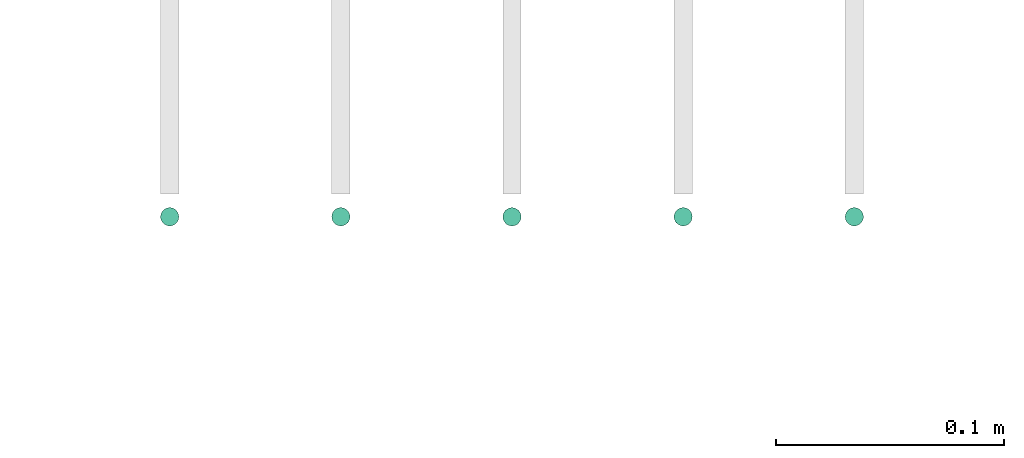
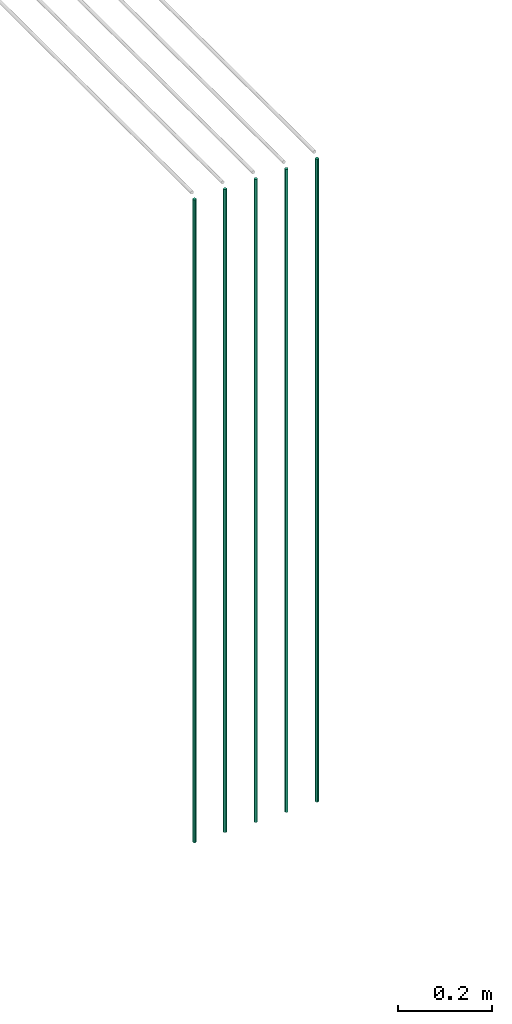
# One storey, part 9 of 89: 5 flow segments.
"""IFC2X3 building model written with IfcOpenShell, lengths in millimetres."""

from ifc_helpers import new_model, entity, si_unit, converted_unit, derived_unit, direction, frame, origin, origin_2d_with_axis, place, context, subcontext, project, spatial, circle, extrude, type_object, element, save


model = new_model("IFC2X3")

# Units and contexts
model_context = context("Model", 3, precision=0.01, world=origin(), true_north=direction((6.12303176911189e-17, 1.0)))
body_context = subcontext(model_context, "Body", "Model", "MODEL_VIEW")
ifc_project = project(units=[si_unit("LENGTHUNIT", "METRE", prefix="MILLI"), si_unit("AREAUNIT", "SQUARE_METRE"), si_unit("VOLUMEUNIT", "CUBIC_METRE"), converted_unit("PLANEANGLEUNIT", "DEGREE", entity("IfcRatioMeasure", 0.0174532925199433), si_unit("PLANEANGLEUNIT", "RADIAN"), dimensions=[0, 0, 0, 0, 0, 0, 0]), si_unit("MASSUNIT", "GRAM", prefix="KILO"), derived_unit("MASSDENSITYUNIT", [(si_unit("MASSUNIT", "GRAM", prefix="KILO"), 1), (si_unit("LENGTHUNIT", "METRE"), -3)]), derived_unit("MOMENTOFINERTIAUNIT", [(si_unit("LENGTHUNIT", "METRE"), 4)]), si_unit("TIMEUNIT", "SECOND"), si_unit("FREQUENCYUNIT", "HERTZ"), si_unit("THERMODYNAMICTEMPERATUREUNIT", "DEGREE_CELSIUS"), derived_unit("THERMALTRANSMITTANCEUNIT", [(si_unit("MASSUNIT", "GRAM", prefix="KILO"), 1), (si_unit("THERMODYNAMICTEMPERATUREUNIT", "KELVIN"), -1), (si_unit("TIMEUNIT", "SECOND"), -3)]), derived_unit("VOLUMETRICFLOWRATEUNIT", [(si_unit("LENGTHUNIT", "METRE"), 3), (si_unit("TIMEUNIT", "SECOND"), -1)]), derived_unit("MASSFLOWRATEUNIT", [(si_unit("MASSUNIT", "GRAM", prefix="KILO"), 1), (si_unit("TIMEUNIT", "SECOND"), -1)]), derived_unit("ROTATIONALFREQUENCYUNIT", [(si_unit("TIMEUNIT", "SECOND"), -1)]), si_unit("ELECTRICCURRENTUNIT", "AMPERE"), si_unit("ELECTRICVOLTAGEUNIT", "VOLT"), si_unit("POWERUNIT", "WATT"), si_unit("FORCEUNIT", "NEWTON", prefix="KILO"), si_unit("ILLUMINANCEUNIT", "LUX"), si_unit("LUMINOUSFLUXUNIT", "LUMEN"), si_unit("LUMINOUSINTENSITYUNIT", "CANDELA"), derived_unit("USERDEFINED", [(si_unit("MASSUNIT", "GRAM", prefix="KILO"), -1), (si_unit("LENGTHUNIT", "METRE"), -2), (si_unit("TIMEUNIT", "SECOND"), 3), (si_unit("LUMINOUSFLUXUNIT", "LUMEN"), 1)]), derived_unit("LINEARVELOCITYUNIT", [(si_unit("LENGTHUNIT", "METRE"), 1), (si_unit("TIMEUNIT", "SECOND"), -1)]), si_unit("PRESSUREUNIT", "PASCAL"), derived_unit("USERDEFINED", [(si_unit("LENGTHUNIT", "METRE"), -2), (si_unit("MASSUNIT", "GRAM", prefix="KILO"), 1), (si_unit("TIMEUNIT", "SECOND"), -2)]), derived_unit("LINEARFORCEUNIT", [(si_unit("MASSUNIT", "GRAM", prefix="KILO"), 1), (si_unit("LENGTHUNIT", "METRE"), 1), (si_unit("TIMEUNIT", "SECOND"), -2), (si_unit("LENGTHUNIT", "METRE"), -1)]), derived_unit("PLANARFORCEUNIT", [(si_unit("MASSUNIT", "GRAM", prefix="KILO"), 1), (si_unit("LENGTHUNIT", "METRE"), 1), (si_unit("TIMEUNIT", "SECOND"), -2), (si_unit("LENGTHUNIT", "METRE"), -2)])], contexts=[model_context])

# Site, building, storey
site_placement = place(None, frame((0.0, -0.00077364408347762, 0.0)))
site = spatial("IfcSite", under=ifc_project, at=site_placement, CompositionType="ELEMENT")
building_placement = place(site_placement, origin())
building = spatial("IfcBuilding", under=site, at=building_placement, CompositionType="ELEMENT")
storey_placement = place(building_placement, frame((0.0, 0.0, 24000.0)))
storey = spatial("IfcBuildingStorey", under=building, at=storey_placement, CompositionType="ELEMENT", Elevation=24000.0)

# Flow segments
pipe_segment_type = type_object("IfcPipeSegmentType", PredefinedType="NOTDEFINED")
for number, where in (
    (1, (45839.1209292422, 16651.4047204552, 1400.0)),
    (2, (45914.1209292421, 16651.4047204552, 1400.0)),
    (3, (46064.1209292421, 16651.4047204552, 1400.0)),
    (4, (45989.1209292421, 16651.4047204552, 1400.0)),
    (5, (46139.1209292421, 16651.4047204552, 1400.0)),
):
    element("IfcFlowSegment", number, at=place(storey_placement, frame(where)), inside=storey, type_object=pipe_segment_type, context=body_context, shape_type="SweptSolid", body=[
        extrude(circle(Radius=4.0, at=origin_2d_with_axis()), frame((5.59527223591499, 5.59527223591499, 0.0)), (0.0, 0.0, 1.0), 1665.00000000002),
    ])

save(model, "model.ifc")
